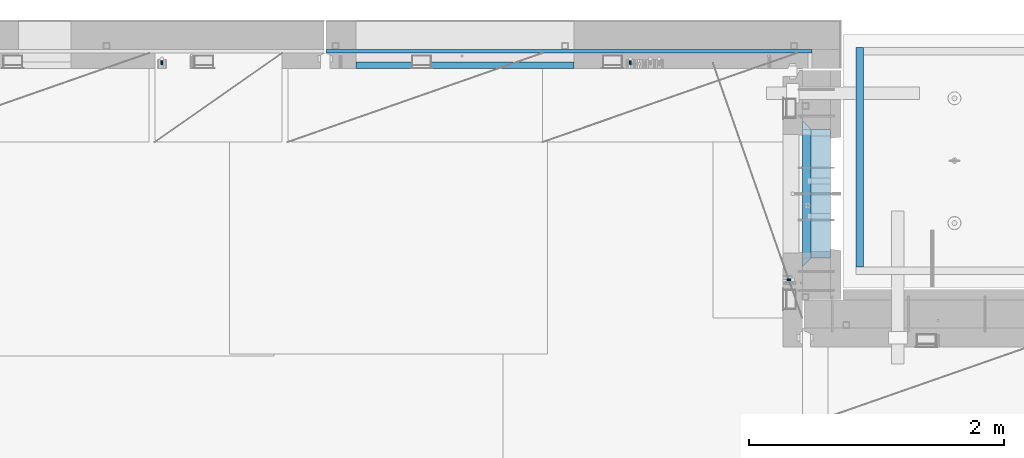
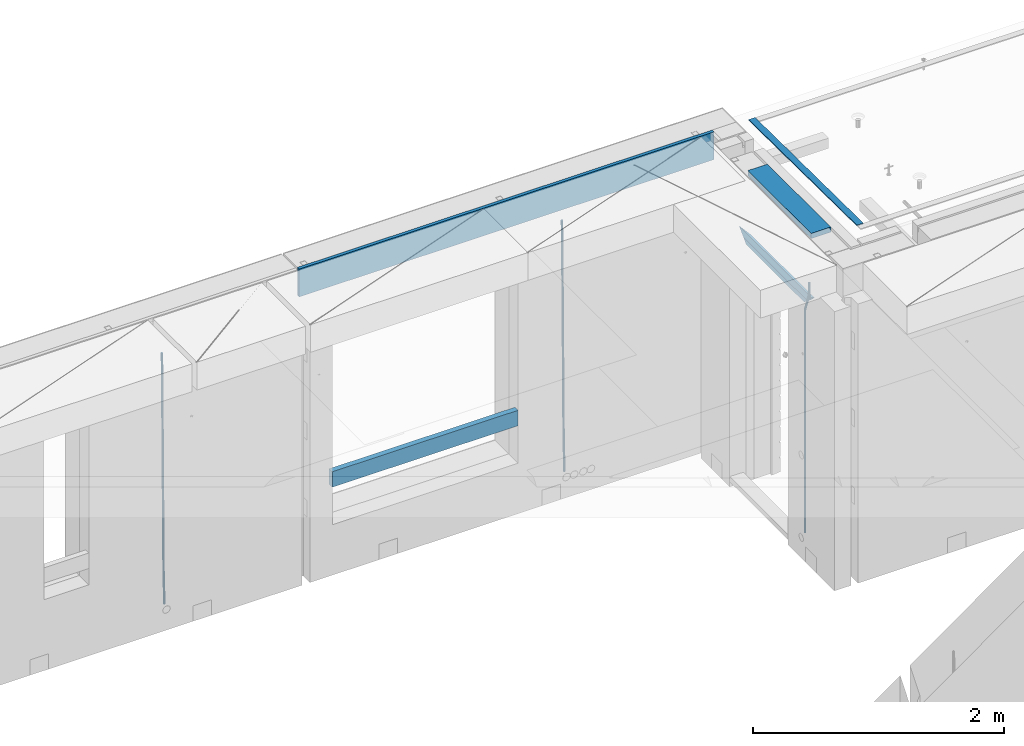
# One storey, part 122 of 341: 9 beams, 4 elements without a shape of their own.
"""IFC2X3 building model written with IfcOpenShell, lengths in millimetres."""

from ifc_helpers import new_model, si_unit, frame, origin_with_axes, place, context, subcontext, project, spatial, faceted_brep, material, type_object, element, aggregate, save


model = new_model("IFC2X3")

# Units and contexts
model_context = context("Model", 3, precision=1e-05, world=origin_with_axes())
body_context = subcontext(model_context, "Body", "Model", "MODEL_VIEW")
ifc_project = project(units=[si_unit("LENGTHUNIT", "METRE", prefix="MILLI"), si_unit("AREAUNIT", "SQUARE_METRE"), si_unit("VOLUMEUNIT", "CUBIC_METRE"), si_unit("MASSUNIT", "GRAM", prefix="KILO"), si_unit("TIMEUNIT", "SECOND"), si_unit("PLANEANGLEUNIT", "RADIAN"), si_unit("SOLIDANGLEUNIT", "STERADIAN"), si_unit("THERMODYNAMICTEMPERATUREUNIT", "DEGREE_CELSIUS"), si_unit("LUMINOUSINTENSITYUNIT", "LUMEN")], contexts=[model_context])

# Site, building, storey
site_placement = place(None, origin_with_axes())
site = spatial("IfcSite", under=ifc_project, at=site_placement, CompositionType="ELEMENT")
building_placement = place(site_placement, origin_with_axes())
building = spatial("IfcBuilding", under=site, at=building_placement, CompositionType="ELEMENT")
storey_placement = place(building_placement, origin_with_axes())
storey = spatial("IfcBuildingStorey", under=building, at=storey_placement, Name="5", CompositionType="ELEMENT", Elevation=0.0)

# Assembly, beams
assembly_1_placement = place(storey_placement, origin_with_axes())
assembly_1 = element("IfcElementAssembly", 1, at=assembly_1_placement, inside=storey, AssemblyPlace="NOTDEFINED", PredefinedType="REINFORCEMENT_UNIT")
ifc_material_1 = material(Name="CONCRETE/C25/30")
beam_type_1 = type_object("IfcBeamType", PredefinedType="NOTDEFINED")
beam_1_placement = place(assembly_1_placement, frame((31494.9951872276, 21060.0002716511, 96140.0), z_axis=(0.0, 0.0, -1.0), x_axis=(0.0, 1.0, 0.0)))
beam_1 = element("IfcBeam", 2, at=beam_1_placement, type_object=beam_type_1, material=ifc_material_1, Name="SK", context=body_context, shape_type="Brep", body=[
    faceted_brep([(70.0000000000164, -35.0, 35.0), (70.0000000000164, 35.0, 35.0), (0.0, -35.0, -35.0), (1079.99961853027, 35.0, 35.0), (1149.99961853027, -35.0, -35.0), (1079.99961853027, -35.0, 35.0)], [[[0, 1, 2]], [[2, 1, 3, 4]], [[0, 2, 4, 5]], [[1, 0, 5, 3]], [[4, 3, 5]]]),
])
beam_type_2 = type_object("IfcBeamType", PredefinedType="NOTDEFINED")
beam_2_placement = place(assembly_1_placement, frame((31494.9951872276, 21130.0002716511, 96080.0), z_axis=(0.0, 0.0, -1.0), x_axis=(0.0, 1.0, 0.0)))
beam_2 = element("IfcBeam", 3, at=beam_2_placement, type_object=beam_type_2, material=ifc_material_1, Name="SK", context=body_context, shape_type="Brep", body=[
    faceted_brep([(0.0, -35.0, -25.0), (43.8457723764295, -35.0, 18.8461538461561), (45.6406441713007, 35.0, 20.6410256410309), (0.0, 35.0, -25.0), (1009.99961853027, 35.0, -25.0), (1009.99961853027, -35.0, -25.0), (966.153464684117, -35.0, 18.8461538461561), (964.358592889246, 35.0, 20.6410256410309)], [[[0, 1, 2, 3]], [[0, 3, 4, 5]], [[1, 0, 5, 6]], [[6, 7, 2, 1]], [[3, 2, 7, 4]], [[6, 5, 4, 7]]]),
])

# Assembly, beam
assembly_2_placement = place(storey_placement, origin_with_axes())
assembly_2 = element("IfcElementAssembly", 4, at=assembly_2_placement, inside=storey, AssemblyPlace="NOTDEFINED", PredefinedType="REINFORCEMENT_UNIT")
ifc_material_2 = material()
beam_type_3 = type_object("IfcBeamType", Name="D20", PredefinedType="NOTDEFINED")
beam_3_placement = place(assembly_2_placement, frame((30110.0000000039, 22654.9999977209, 93990.0), z_axis=(-0.000205762999925498, 0.999642804629538, -0.0267249099901004), x_axis=(4.30000201928125e-08, 0.0267249099948059, 0.999642825806181)))
beam_3 = element("IfcBeam", 5, at=beam_3_placement, type_object=beam_type_3, material=ifc_material_2, Name="JM20", ObjectType="D20", context=body_context, shape_type="Brep", body=[
    faceted_brep([(0.0, -10.0, 0.0), (-4.19531716033816e-08, -7.07106781186667, -7.07106781187031), (60.4266690400545, -7.0710677960451, -7.07106780570757), (60.4266690441291, -9.99999998418934, 6.15546014159918e-09), (0.0, 0.0, -10.0), (60.426669036824, 1.58106558956206e-08, -9.99999999384454), (4.196772351861e-08, 7.07106781186303, -7.07106781186667), (60.4266690363438, 7.07106782768096, -7.07106780570757), (0.0, 10.0, 0.0), (60.4266690388904, 10.0000000158179, 6.15182216279209e-09), (4.196772351861e-08, 7.07106781185939, 7.07106781185939), (60.4266690429649, 7.07106782768096, 7.07106781802577), (0.0, 0.0, 10.0), (60.4266690461809, 1.58179318532348e-08, 10.0000000061555), (-4.19531716033816e-08, -7.07106781187031, 7.07106781185939), (60.4266690466611, -7.07106779605238, 7.07106781802213), (61.0378400410118, -7.07106779588503, -7.07106780564936), (60.991799419251, -9.99999998403655, 6.21366780251265e-09), (61.0569027789461, 1.5985278878361e-08, -9.99999999378269), (61.0378209396877, 7.07106782784831, -7.07106780564936), (60.9917724058905, 10.0000000159635, 6.21366780251265e-09), (60.9457317841297, 7.07106782781193, 7.0710678180767), (60.9266690461809, 1.59488990902901e-08, 10.0000000062028), (60.9457508854539, -7.07106779591413, 7.0710678180767), (61.6489592143771, -7.07106614513759, -7.06310863441468), (61.5568818710308, -9.9999984576425, 0.00735959856683621), (61.6870830769039, 1.71821739058942e-06, -9.99179257185824), (61.6489210170112, 7.07106947854481, -7.06310888312146), (61.556827851804, 10.0000015422847, 0.00735924683976918), (61.4647505084577, 7.07106922979438, 7.07782747982128), (61.4266266459163, 1.36643211590126e-06, 10.0065114172685), (61.464788705809, -7.07106639389531, 7.07782772852806), (176.543135720174, -7.07075579406956, -5.56673531796696), (176.451058376813, -9.99968810657447, 1.50373291501455), (176.581259582701, 0.000312069292704109, -8.49541925541052), (176.543097522794, 7.07137982961285, -5.56673556667374), (176.451004357587, 10.00031189336, 1.50373256329476), (176.35892701424, 7.07137958085514, 8.57420079627263), (176.320803151699, 0.000311717507429421, 11.5028847337162), (176.358965211621, -7.07075604281999, 8.57420104497578), (177.098753836006, -7.07075429323595, -5.55949898843028), (176.98362511232, -9.99968666800123, 1.510669025065), (177.146421932586, 0.000313595905026887, -8.48805862247536), (177.098706077581, 7.07138133041735, -5.55949936166144), (176.983557571715, 10.0003133318824, 1.51066849724157), (176.868428848029, 7.07138095712435, 8.58083651073321), (176.820760751449, 0.000313067976094317, 11.5093961447819), (176.868476606425, -7.07075466652896, 8.58083688396073), (177.654312950661, -7.07075204110879, -5.54863964998367), (177.516135294456, -9.99968450931192, 1.52107783331303), (177.711524267797, 0.000315886711177882, -8.47701274570863), (177.654255632195, 7.07138358250813, -5.54864021007961), (177.516054233929, 10.0003154905207, 1.5210770412159), (177.377876577739, 7.0713830223176, 8.59079452451624), (177.320665260588, 0.000315094497636892, 11.5191676202448), (177.377933896176, -7.07075260129932, 8.59079508461218), (299.436796249574, -7.07025836271714, -3.1681962331204), (299.298618593355, -9.99919083092027, 3.90152125031091), (299.494007566798, 0.000809565110102994, -6.09656932889993), (299.436738931283, 7.07187726089978, -3.16819679320906), (299.298537533061, 10.0008091689197, 3.90152045822106), (299.160359876842, 7.07187670072017, 10.9712379416487), (299.103148559603, 0.000808772889286047, 13.8996110374392), (299.160417195119, -7.07025892290039, 10.9712385017483), (299.98743051647, -7.07025613056248, -3.15743315966392), (299.971788958996, -9.99918809853989, 3.91467979818117), (299.993912075952, 0.000811591617093654, -6.08679785393178), (299.987423933868, 7.07187949325817, -3.1574327280432), (299.971753863239, 10.0008119014747, 3.91467990454839), (299.95611230444, 7.07187992653053, 10.9867922621015), (299.949630744944, 0.000812204350950196, 13.9161569563694), (299.956118887014, -7.07025569729012, 10.9867918304735), (300.538107039494, -7.07025785017686, -3.16575821840888), (300.644985195438, -9.99919020432935, 3.90450175465594), (300.493854948218, 0.000810030429420294, -6.09435592770024), (300.538151196495, 7.071877773491, -3.16575855385963), (300.645047642858, 10.0008097955724, 3.90450128024895), (300.751925798773, 7.07187744142357, 10.9747612533101), (300.796177890064, 0.000809560813650023, 13.9033589625978), (300.751881641787, -7.07025818224065, 10.9747615887682), (2293.36490490142, -7.07648090940347, -33.2930642912361), (2293.47178305736, -10.0054132635523, -26.2228043181785), (2293.32065281013, -0.00541302880083094, -36.2216620005347), (2293.36494905842, 7.06565471425711, -33.2930646266868), (2293.47184550477, 9.99458673634581, -26.2228047925819), (2293.57872366071, 7.06565438219332, -19.1525448195243), (2293.62297575199, -0.00541349841296324, -16.2239471102366), (2293.57867950371, -7.0764812414709, -19.1525444840736), (2294.0658245362, -7.07648309818615, -33.3036607065333), (2294.05312277409, -10.0054150789219, -26.2315929392535), (2294.10928714235, -0.00541549149056664, -36.2335844756526), (2294.15805078732, 7.06565223761572, -33.3050546393533), (2294.18355038921, 9.99458451388637, -26.2335642579346), (2294.17084862708, 7.06565253314329, -19.1614964906439), (2294.12738602093, -0.00541507354500936, -16.2315727215355), (2294.07862237596, -7.07648280265857, -19.1601025578348), (2294.76670261032, -7.08562269121467, -33.294332712383), (2294.63442802057, -10.0129954178956, -26.2238563411993), (2294.89787471293, -0.0156988342423574, -36.2230891548279), (2294.95110548967, 7.05531064255774, -33.2944998654275), (2294.89521307347, 9.98530428734011, -26.2240927312887), (2294.76293848372, 7.0579315606592, -19.1536163601049), (2294.63176638114, -0.0119922963167483, -16.2248599176673), (2294.57853560438, -7.08300177311321, -19.1534492070678), (2316.52657204497, -7.36937582653991, -33.0047303660212), (2316.39429745522, -10.2967485532172, -25.9342539948302), (2316.65774414754, -0.299451969567599, -35.9334868084661), (2316.7109749243, 6.7715575072325, -33.0048975190657), (2316.65508250811, 9.70155115201487, -25.9344903849269), (2316.52280791836, 6.7741784253376, -18.8640140137468), (2316.39163581574, -0.295745431634714, -15.9352575713092), (2316.33840503903, -7.36675490843481, -18.863846860706), (2317.16202064224, -7.37766220584308, -32.9962731735213), (2317.05438744847, -10.3053562613532, -25.9254688497131), (2317.23607125619, -0.306993473008333, -35.925789846493), (2317.23316144495, 6.76474808850253, -32.9979477328052), (2317.15499573652, 9.6950321815566, -25.9278370341635), (2317.04736254275, 6.7673381260538, -18.8570327103698), (2316.97331192881, -0.303330606784584, -15.9275160373909), (2316.97622174003, -7.37507216829545, -18.8553581510787), (2317.79752306276, -7.37578610372293, -32.9880110666527), (2317.71453320107, -10.3033876998124, -25.9168792378296), (2317.81444760226, -0.305295583297266, -35.918287695793), (2317.75539265381, 6.76628640723357, -32.9911928173897), (2317.65495180529, 9.69652304524061, -25.9213789128698), (2317.5719619436, 6.76892144914746, -18.8502470840467), (2317.55503740412, -0.301569071270933, -15.9199704549137), (2317.61409235255, -7.3731510618054, -18.847065333317), (2417.8183084176, -7.07752398473531, -31.6906369377139), (2417.73531855589, -10.0051255808248, -24.6195051088798), (2417.83523295709, -0.007033464313281, -34.6209135668432), (2417.77617800863, 7.06454852621755, -31.6938186884508), (2417.67573716014, 9.99478516423187, -24.6240047839383), (2417.59274729842, 7.06718356813872, -17.5528729551006), (2417.57582275895, -0.00330695228694822, -14.6225963259749), (2417.6348777074, -7.07488894281778, -17.5496912043673)], [[[0, 1, 2, 3]], [[1, 4, 5, 2]], [[4, 6, 7, 5]], [[6, 8, 9, 7]], [[8, 10, 11, 9]], [[10, 12, 13, 11]], [[12, 14, 15, 13]], [[14, 0, 3, 15]], [[14, 12, 10, 8, 6, 4, 1, 0]], [[3, 2, 16, 17]], [[2, 5, 18, 16]], [[5, 7, 19, 18]], [[7, 9, 20, 19]], [[9, 11, 21, 20]], [[11, 13, 22, 21]], [[13, 15, 23, 22]], [[15, 3, 17, 23]], [[17, 16, 24, 25]], [[16, 18, 26, 24]], [[18, 19, 27, 26]], [[19, 20, 28, 27]], [[20, 21, 29, 28]], [[21, 22, 30, 29]], [[22, 23, 31, 30]], [[23, 17, 25, 31]], [[25, 24, 32, 33]], [[24, 26, 34, 32]], [[26, 27, 35, 34]], [[27, 28, 36, 35]], [[28, 29, 37, 36]], [[29, 30, 38, 37]], [[30, 31, 39, 38]], [[31, 25, 33, 39]], [[33, 32, 40, 41]], [[32, 34, 42, 40]], [[34, 35, 43, 42]], [[35, 36, 44, 43]], [[36, 37, 45, 44]], [[37, 38, 46, 45]], [[38, 39, 47, 46]], [[39, 33, 41, 47]], [[41, 40, 48, 49]], [[40, 42, 50, 48]], [[42, 43, 51, 50]], [[43, 44, 52, 51]], [[44, 45, 53, 52]], [[45, 46, 54, 53]], [[46, 47, 55, 54]], [[47, 41, 49, 55]], [[49, 48, 56, 57]], [[48, 50, 58, 56]], [[50, 51, 59, 58]], [[51, 52, 60, 59]], [[52, 53, 61, 60]], [[53, 54, 62, 61]], [[54, 55, 63, 62]], [[55, 49, 57, 63]], [[57, 56, 64, 65]], [[56, 58, 66, 64]], [[58, 59, 67, 66]], [[59, 60, 68, 67]], [[60, 61, 69, 68]], [[61, 62, 70, 69]], [[62, 63, 71, 70]], [[63, 57, 65, 71]], [[65, 64, 72, 73]], [[64, 66, 74, 72]], [[66, 67, 75, 74]], [[67, 68, 76, 75]], [[68, 69, 77, 76]], [[69, 70, 78, 77]], [[70, 71, 79, 78]], [[71, 65, 73, 79]], [[73, 72, 80, 81]], [[72, 74, 82, 80]], [[74, 75, 83, 82]], [[75, 76, 84, 83]], [[76, 77, 85, 84]], [[77, 78, 86, 85]], [[78, 79, 87, 86]], [[79, 73, 81, 87]], [[81, 80, 88, 89]], [[80, 82, 90, 88]], [[82, 83, 91, 90]], [[83, 84, 92, 91]], [[84, 85, 93, 92]], [[85, 86, 94, 93]], [[86, 87, 95, 94]], [[87, 81, 89, 95]], [[89, 88, 96, 97]], [[88, 90, 98, 96]], [[90, 91, 99, 98]], [[91, 92, 100, 99]], [[92, 93, 101, 100]], [[93, 94, 102, 101]], [[94, 95, 103, 102]], [[95, 89, 97, 103]], [[97, 96, 104, 105]], [[96, 98, 106, 104]], [[98, 99, 107, 106]], [[99, 100, 108, 107]], [[100, 101, 109, 108]], [[101, 102, 110, 109]], [[102, 103, 111, 110]], [[103, 97, 105, 111]], [[105, 104, 112, 113]], [[104, 106, 114, 112]], [[106, 107, 115, 114]], [[107, 108, 116, 115]], [[108, 109, 117, 116]], [[109, 110, 118, 117]], [[110, 111, 119, 118]], [[111, 105, 113, 119]], [[113, 112, 120, 121]], [[112, 114, 122, 120]], [[114, 115, 123, 122]], [[115, 116, 124, 123]], [[116, 117, 125, 124]], [[117, 118, 126, 125]], [[118, 119, 127, 126]], [[119, 113, 121, 127]], [[121, 120, 128, 129]], [[120, 122, 130, 128]], [[122, 123, 131, 130]], [[123, 124, 132, 131]], [[124, 125, 133, 132]], [[125, 126, 134, 133]], [[126, 127, 135, 134]], [[127, 121, 129, 135]], [[130, 131, 132, 133, 134, 135, 129, 128]]]),
])

assembly_3_placement = place(storey_placement, origin_with_axes())
assembly_3 = element("IfcElementAssembly", 6, at=assembly_3_placement, inside=storey, AssemblyPlace="NOTDEFINED", PredefinedType="REINFORCEMENT_UNIT")
beam_4_placement = place(assembly_3_placement, frame((26430.0000000039, 22654.999995444, 93990.0), z_axis=(-0.000205762999925498, 0.999642804629538, -0.0267249099901004), x_axis=(4.30000201928125e-08, 0.0267249099948059, 0.999642825806181)))
beam_4 = element("IfcBeam", 7, at=beam_4_placement, type_object=beam_type_3, material=ifc_material_2, Name="JM20", ObjectType="D20", context=body_context, shape_type="Brep", body=[
    faceted_brep([(0.0, -10.0, 0.0), (-4.19531716033816e-08, -7.07106781186667, -7.07106781187031), (60.4266690400545, -7.0710677960451, -7.07106780570757), (60.4266690441291, -9.99999998418934, 6.15546014159918e-09), (0.0, 0.0, -10.0), (60.426669036824, 1.58106558956206e-08, -9.99999999384454), (4.196772351861e-08, 7.07106781186303, -7.07106781186667), (60.4266690363438, 7.07106782768096, -7.07106780570757), (0.0, 10.0, 0.0), (60.4266690388904, 10.0000000158179, 6.15182216279209e-09), (4.196772351861e-08, 7.07106781185939, 7.07106781185939), (60.4266690429649, 7.07106782768096, 7.07106781802577), (0.0, 0.0, 10.0), (60.4266690461809, 1.58179318532348e-08, 10.0000000061555), (-4.19531716033816e-08, -7.07106781187031, 7.07106781185939), (60.4266690466611, -7.07106779605238, 7.07106781802213), (61.0378400410118, -7.07106779588503, -7.07106780564936), (60.991799419251, -9.99999998403655, 6.21366780251265e-09), (61.0569027789461, 1.5985278878361e-08, -9.99999999378269), (61.0378209396877, 7.07106782784831, -7.07106780564936), (60.9917724058905, 10.0000000159635, 6.21366780251265e-09), (60.9457317841297, 7.07106782781193, 7.0710678180767), (60.9266690461809, 1.59488990902901e-08, 10.0000000062028), (60.9457508854539, -7.07106779591413, 7.0710678180767), (61.6489592143771, -7.07106614513759, -7.06310863441468), (61.5568818710308, -9.9999984576425, 0.00735959856683621), (61.6870830769039, 1.71821739058942e-06, -9.99179257185824), (61.6489210170112, 7.07106947854481, -7.06310888312146), (61.556827851804, 10.0000015422847, 0.00735924683976918), (61.4647505084577, 7.07106922979438, 7.07782747982128), (61.4266266459163, 1.36643211590126e-06, 10.0065114172685), (61.464788705809, -7.07106639389531, 7.07782772852806), (176.543135720174, -7.07075579406956, -5.56673531796696), (176.451058376813, -9.99968810657447, 1.50373291501455), (176.581259582701, 0.000312069292704109, -8.49541925541052), (176.543097522794, 7.07137982961285, -5.56673556667374), (176.451004357587, 10.00031189336, 1.50373256329476), (176.35892701424, 7.07137958085514, 8.57420079627263), (176.320803151699, 0.000311717507429421, 11.5028847337162), (176.358965211621, -7.07075604281999, 8.57420104497578), (177.098753836006, -7.07075429323595, -5.55949898843028), (176.98362511232, -9.99968666800123, 1.510669025065), (177.146421932586, 0.000313595905026887, -8.48805862247536), (177.098706077581, 7.07138133041735, -5.55949936166144), (176.983557571715, 10.0003133318824, 1.51066849724157), (176.868428848029, 7.07138095712435, 8.58083651073321), (176.820760751449, 0.000313067976094317, 11.5093961447819), (176.868476606425, -7.07075466652896, 8.58083688396073), (177.654312950661, -7.07075204110879, -5.54863964998367), (177.516135294456, -9.99968450931192, 1.52107783331303), (177.711524267797, 0.000315886711177882, -8.47701274570863), (177.654255632195, 7.07138358250813, -5.54864021007961), (177.516054233929, 10.0003154905207, 1.5210770412159), (177.377876577739, 7.0713830223176, 8.59079452451624), (177.320665260588, 0.000315094497636892, 11.5191676202448), (177.377933896176, -7.07075260129932, 8.59079508461218), (299.436796249574, -7.07025836271714, -3.1681962331204), (299.298618593355, -9.99919083092027, 3.90152125031091), (299.494007566798, 0.000809565110102994, -6.09656932889993), (299.436738931283, 7.07187726089978, -3.16819679320906), (299.298537533061, 10.0008091689197, 3.90152045822106), (299.160359876842, 7.07187670072017, 10.9712379416487), (299.103148559603, 0.000808772889286047, 13.8996110374392), (299.160417195119, -7.07025892290039, 10.9712385017483), (299.98743051647, -7.07025613056248, -3.15743315966392), (299.971788958996, -9.99918809853989, 3.91467979818117), (299.993912075952, 0.000811591617093654, -6.08679785393178), (299.987423933868, 7.07187949325817, -3.1574327280432), (299.971753863239, 10.0008119014747, 3.91467990454839), (299.95611230444, 7.07187992653053, 10.9867922621015), (299.949630744944, 0.000812204350950196, 13.9161569563694), (299.956118887014, -7.07025569729012, 10.9867918304735), (300.538107039494, -7.07025785017686, -3.16575821840888), (300.644985195438, -9.99919020432935, 3.90450175465594), (300.493854948218, 0.000810030429420294, -6.09435592770024), (300.538151196495, 7.071877773491, -3.16575855385963), (300.645047642858, 10.0008097955724, 3.90450128024895), (300.751925798773, 7.07187744142357, 10.9747612533101), (300.796177890064, 0.000809560813650023, 13.9033589625978), (300.751881641787, -7.07025818224065, 10.9747615887682), (2293.36490490142, -7.07648090940347, -33.2930642912361), (2293.47178305736, -10.0054132635523, -26.2228043181785), (2293.32065281013, -0.00541302880083094, -36.2216620005347), (2293.36494905842, 7.06565471425711, -33.2930646266868), (2293.47184550477, 9.99458673634581, -26.2228047925819), (2293.57872366071, 7.06565438219332, -19.1525448195243), (2293.62297575199, -0.00541349841296324, -16.2239471102366), (2293.57867950371, -7.0764812414709, -19.1525444840736), (2294.0658245362, -7.07648309818615, -33.3036607065333), (2294.05312277409, -10.0054150789219, -26.2315929392535), (2294.10928714235, -0.00541549149056664, -36.2335844756526), (2294.15805078732, 7.06565223761572, -33.3050546393533), (2294.18355038921, 9.99458451388637, -26.2335642579346), (2294.17084862708, 7.06565253314329, -19.1614964906439), (2294.12738602093, -0.00541507354500936, -16.2315727215355), (2294.07862237596, -7.07648280265857, -19.1601025578348), (2294.76670261032, -7.08562269121467, -33.294332712383), (2294.63442802057, -10.0129954178956, -26.2238563411993), (2294.89787471293, -0.0156988342423574, -36.2230891548279), (2294.95110548967, 7.05531064255774, -33.2944998654275), (2294.89521307347, 9.98530428734011, -26.2240927312887), (2294.76293848372, 7.0579315606592, -19.1536163601049), (2294.63176638114, -0.0119922963167483, -16.2248599176673), (2294.57853560438, -7.08300177311321, -19.1534492070678), (2316.52657204497, -7.36937582653991, -33.0047303660212), (2316.39429745522, -10.2967485532172, -25.9342539948302), (2316.65774414754, -0.299451969567599, -35.9334868084661), (2316.7109749243, 6.7715575072325, -33.0048975190657), (2316.65508250811, 9.70155115201487, -25.9344903849269), (2316.52280791836, 6.7741784253376, -18.8640140137468), (2316.39163581574, -0.295745431634714, -15.9352575713092), (2316.33840503903, -7.36675490843481, -18.863846860706), (2317.16202064224, -7.37766220584308, -32.9962731735213), (2317.05438744847, -10.3053562613532, -25.9254688497131), (2317.23607125619, -0.306993473008333, -35.925789846493), (2317.23316144495, 6.76474808850253, -32.9979477328052), (2317.15499573652, 9.6950321815566, -25.9278370341635), (2317.04736254275, 6.7673381260538, -18.8570327103698), (2316.97331192881, -0.303330606784584, -15.9275160373909), (2316.97622174003, -7.37507216829545, -18.8553581510787), (2317.79752306276, -7.37578610372293, -32.9880110666527), (2317.71453320107, -10.3033876998124, -25.9168792378296), (2317.81444760226, -0.305295583297266, -35.918287695793), (2317.75539265381, 6.76628640723357, -32.9911928173897), (2317.65495180529, 9.69652304524061, -25.9213789128698), (2317.5719619436, 6.76892144914746, -18.8502470840467), (2317.55503740412, -0.301569071270933, -15.9199704549137), (2317.61409235255, -7.3731510618054, -18.847065333317), (2417.8183084176, -7.07752398473531, -31.6906369377139), (2417.73531855589, -10.0051255808248, -24.6195051088798), (2417.83523295709, -0.007033464313281, -34.6209135668432), (2417.77617800863, 7.06454852621755, -31.6938186884508), (2417.67573716014, 9.99478516423187, -24.6240047839383), (2417.59274729842, 7.06718356813872, -17.5528729551006), (2417.57582275895, -0.00330695228694822, -14.6225963259749), (2417.6348777074, -7.07488894281778, -17.5496912043673)], [[[0, 1, 2, 3]], [[1, 4, 5, 2]], [[4, 6, 7, 5]], [[6, 8, 9, 7]], [[8, 10, 11, 9]], [[10, 12, 13, 11]], [[12, 14, 15, 13]], [[14, 0, 3, 15]], [[14, 12, 10, 8, 6, 4, 1, 0]], [[3, 2, 16, 17]], [[2, 5, 18, 16]], [[5, 7, 19, 18]], [[7, 9, 20, 19]], [[9, 11, 21, 20]], [[11, 13, 22, 21]], [[13, 15, 23, 22]], [[15, 3, 17, 23]], [[17, 16, 24, 25]], [[16, 18, 26, 24]], [[18, 19, 27, 26]], [[19, 20, 28, 27]], [[20, 21, 29, 28]], [[21, 22, 30, 29]], [[22, 23, 31, 30]], [[23, 17, 25, 31]], [[25, 24, 32, 33]], [[24, 26, 34, 32]], [[26, 27, 35, 34]], [[27, 28, 36, 35]], [[28, 29, 37, 36]], [[29, 30, 38, 37]], [[30, 31, 39, 38]], [[31, 25, 33, 39]], [[33, 32, 40, 41]], [[32, 34, 42, 40]], [[34, 35, 43, 42]], [[35, 36, 44, 43]], [[36, 37, 45, 44]], [[37, 38, 46, 45]], [[38, 39, 47, 46]], [[39, 33, 41, 47]], [[41, 40, 48, 49]], [[40, 42, 50, 48]], [[42, 43, 51, 50]], [[43, 44, 52, 51]], [[44, 45, 53, 52]], [[45, 46, 54, 53]], [[46, 47, 55, 54]], [[47, 41, 49, 55]], [[49, 48, 56, 57]], [[48, 50, 58, 56]], [[50, 51, 59, 58]], [[51, 52, 60, 59]], [[52, 53, 61, 60]], [[53, 54, 62, 61]], [[54, 55, 63, 62]], [[55, 49, 57, 63]], [[57, 56, 64, 65]], [[56, 58, 66, 64]], [[58, 59, 67, 66]], [[59, 60, 68, 67]], [[60, 61, 69, 68]], [[61, 62, 70, 69]], [[62, 63, 71, 70]], [[63, 57, 65, 71]], [[65, 64, 72, 73]], [[64, 66, 74, 72]], [[66, 67, 75, 74]], [[67, 68, 76, 75]], [[68, 69, 77, 76]], [[69, 70, 78, 77]], [[70, 71, 79, 78]], [[71, 65, 73, 79]], [[73, 72, 80, 81]], [[72, 74, 82, 80]], [[74, 75, 83, 82]], [[75, 76, 84, 83]], [[76, 77, 85, 84]], [[77, 78, 86, 85]], [[78, 79, 87, 86]], [[79, 73, 81, 87]], [[81, 80, 88, 89]], [[80, 82, 90, 88]], [[82, 83, 91, 90]], [[83, 84, 92, 91]], [[84, 85, 93, 92]], [[85, 86, 94, 93]], [[86, 87, 95, 94]], [[87, 81, 89, 95]], [[89, 88, 96, 97]], [[88, 90, 98, 96]], [[90, 91, 99, 98]], [[91, 92, 100, 99]], [[92, 93, 101, 100]], [[93, 94, 102, 101]], [[94, 95, 103, 102]], [[95, 89, 97, 103]], [[97, 96, 104, 105]], [[96, 98, 106, 104]], [[98, 99, 107, 106]], [[99, 100, 108, 107]], [[100, 101, 109, 108]], [[101, 102, 110, 109]], [[102, 103, 111, 110]], [[103, 97, 105, 111]], [[105, 104, 112, 113]], [[104, 106, 114, 112]], [[106, 107, 115, 114]], [[107, 108, 116, 115]], [[108, 109, 117, 116]], [[109, 110, 118, 117]], [[110, 111, 119, 118]], [[111, 105, 113, 119]], [[113, 112, 120, 121]], [[112, 114, 122, 120]], [[114, 115, 123, 122]], [[115, 116, 124, 123]], [[116, 117, 125, 124]], [[117, 118, 126, 125]], [[118, 119, 127, 126]], [[119, 113, 121, 127]], [[121, 120, 128, 129]], [[120, 122, 130, 128]], [[122, 123, 131, 130]], [[123, 124, 132, 131]], [[124, 125, 133, 132]], [[125, 126, 134, 133]], [[126, 127, 135, 134]], [[127, 121, 129, 135]], [[130, 131, 132, 133, 134, 135, 129, 128]]]),
])
aggregate(assembly_3, [beam_4])

# Beam
beam_5_placement = place(assembly_1_placement, frame((31384.9951872298, 20959.9999999916, 96407.5), z_axis=(-0.999999913638316, 0.000415599999849952, 0.0), x_axis=(0.0, 0.0, -1.0)))
beam_5 = element("IfcBeam", 8, at=beam_5_placement, type_object=beam_type_3, material=ifc_material_2, Name="JM20", ObjectType="D20", context=body_context, shape_type="Brep", body=[
    faceted_brep([(0.0, -10.0, 0.0), (-4.19531716033816e-08, -7.07106781186667, -7.07106781187031), (113.248091332178, -7.0710684840451, -7.0710678117357), (113.248091314759, -10.0000006713562, -2.51020537689328e-10), (0.0, 0.0, -10.0), (113.248091374131, -6.72178430249915e-07, -9.99999999986903), (4.196772351861e-08, 7.07106781186303, -7.07106781186667), (113.248091416113, 7.07106713968824, -7.07106781173934), (0.0, 10.0, 0.0), (113.248091433488, 9.99999932782521, 1.30967237055302e-10), (4.196772351861e-08, 7.07106781185939, 7.07106781185939), (113.248091416113, 7.0710671396846, 7.071067811994), (0.0, 0.0, 10.0), (113.248091374131, -6.72174792271107e-07, 10.0000000001273), (-4.19531716033816e-08, -7.07106781187031, 7.07106781185939), (113.248091332178, -7.0710684840451, 7.071067811994), (130.699843527167, -7.06993249763036, -4.33745683788584), (128.538066582521, -9.99900540317321, 2.39499413731755), (131.594536475241, 0.00119355250353692, -7.12624594330919), (130.698046432328, 7.07220300913468, -4.33773834422391), (128.535525107087, 10.0009944322555, 2.39459602660281), (126.373748162892, 7.07192152754578, 9.1270470011732), (125.479055214906, 0.000795477419160306, 11.9158361066184), (126.37554525779, -7.07021397921199, 9.12732850753673), (240.336258550378, -7.05529970173666, 30.8729495437874), (238.174481606227, -9.98437260450009, 37.6054005176375), (241.230951498423, 0.0158263482953771, 28.0841604381058), (240.334461455612, 7.0868358050102, 30.8726680369582), (238.171940130502, 10.0156272283348, 37.6050024077231), (236.010163186409, 7.08655432384694, 44.3374533824244), (235.115470238379, 0.0154282738185429, 47.1262424881097), (236.011960281176, -7.05558118289991, 44.3377348892536), (253.461915329972, -7.05444528127919, 32.9289287376414), (253.46191532613, -9.98337746617108, 39.9999965521893), (253.461915339081, 0.0166225284556276, 29.9999965443676), (253.461915348205, 7.08769034247234, 32.9289287273205), (253.461915352003, 10.0166225357716, 39.9999965370152), (253.461915348293, 7.08769035281148, 47.0710643509774), (253.461915339183, 0.0166225430875784, 49.999996544273), (253.46191533003, -7.05444527093641, 47.0710643613093), (2417.50000002384, -7.0544364694706, 32.9289287374122), (2417.5000000337, -9.98336865393321, 39.9999965507959), (2417.49999999997, 0.0166313408753922, 29.9999965456082), (2417.49999997609, 7.08769915426274, 32.9289287300708), (2417.4999999662, 10.0166313460668, 39.9999965404204), (2417.49999997608, 7.08769916160054, 47.0710643538114), (2417.49999999994, 0.0166313512581837, 49.9999965456154), (2417.50000002382, -7.05443646212916, 47.0710643611455)], [[[0, 1, 2, 3]], [[1, 4, 5, 2]], [[4, 6, 7, 5]], [[6, 8, 9, 7]], [[8, 10, 11, 9]], [[10, 12, 13, 11]], [[12, 14, 15, 13]], [[14, 0, 3, 15]], [[14, 12, 10, 8, 6, 4, 1, 0]], [[3, 2, 16, 17]], [[2, 5, 18, 16]], [[5, 7, 19, 18]], [[7, 9, 20, 19]], [[9, 11, 21, 20]], [[11, 13, 22, 21]], [[13, 15, 23, 22]], [[15, 3, 17, 23]], [[17, 16, 24, 25]], [[16, 18, 26, 24]], [[18, 19, 27, 26]], [[19, 20, 28, 27]], [[20, 21, 29, 28]], [[21, 22, 30, 29]], [[22, 23, 31, 30]], [[23, 17, 25, 31]], [[25, 24, 32, 33]], [[24, 26, 34, 32]], [[26, 27, 35, 34]], [[27, 28, 36, 35]], [[28, 29, 37, 36]], [[29, 30, 38, 37]], [[30, 31, 39, 38]], [[31, 25, 33, 39]], [[33, 32, 40, 41]], [[32, 34, 42, 40]], [[34, 35, 43, 42]], [[35, 36, 44, 43]], [[36, 37, 45, 44]], [[37, 38, 46, 45]], [[38, 39, 47, 46]], [[39, 33, 41, 47]], [[42, 43, 44, 45, 46, 47, 41, 40]]]),
])

ifc_material_3 = material(Name="TIMBER/T24")
beam_type_4 = type_object("IfcBeamType", PredefinedType="NOTDEFINED")
beam_6_placement = place(assembly_2_placement, frame((29665.0002980493, 22644.9998418812, 94685.0), z_axis=(0.0, 0.0, 1.0), x_axis=(-1.0, 3.00000001838171e-08, 0.0)))
beam_6 = element("IfcBeam", 9, at=beam_6_placement, type_object=beam_type_4, material=ifc_material_3, context=body_context, shape_type="Brep", body=[
    faceted_brep([(-3.63797880709171e-12, 24.9999999999964, -75.0), (-3.63797880709171e-12, 24.9999999999964, 75.0), (1710.0, 25.0, 75.0), (1710.0, 25.0, -75.0), (0.0, -25.0000000000073, 75.0), (1709.99999999999, -25.0, 75.0), (0.0, -25.0000000000073, -75.0), (1709.99999999999, -25.0, -75.0)], [[[0, 1, 2, 3]], [[1, 4, 5, 2]], [[4, 6, 7, 5]], [[6, 0, 3, 7]], [[5, 7, 3, 2]], [[6, 4, 1, 0]]]),
])

# Assembly, beam
assembly_4_placement = place(storey_placement, origin_with_axes())
assembly_4 = element("IfcElementAssembly", 10, at=assembly_4_placement, inside=storey, AssemblyPlace="NOTDEFINED", PredefinedType="REINFORCEMENT_UNIT")
ifc_material_4 = material(Name="CONCRETE/Concrete_Undefined")
beam_type_5 = type_object("IfcBeamType", PredefinedType="NOTDEFINED")
beam_7_placement = place(assembly_4_placement, frame((31909.9986098709, 21060.0524822207, 96725.2791116282), z_axis=(7.99999906921644e-09, 0.0107912409985276, 0.999941772863656), x_axis=(7.22999999800065e-07, 0.999941772863395, -0.0107912409985247)))
beam_7 = element("IfcBeam", 11, at=beam_7_placement, type_object=beam_type_5, material=ifc_material_4, context=body_context, shape_type="Brep", body=[
    faceted_brep([(2.5465851649642e-11, 29.9999999999982, -4.99999999998545), (-2.91038304567337e-11, 29.9999999999982, 5.0), (1725.04446838825, 29.9999999999927, 4.99999999998545), (1725.04446838825, 29.9999999999927, -5.00000000001455), (-2.5465851649642e-11, -30.0000000000018, 5.0), (1725.04446838824, -30.0000000000073, 4.99999999998545), (2.72848410531878e-11, -30.0000000000018, -4.99999999998545), (1725.04446838824, -30.0000000000073, -5.0)], [[[0, 1, 2, 3]], [[1, 4, 5, 2]], [[4, 6, 7, 5]], [[6, 0, 3, 7]], [[5, 7, 3, 2]], [[6, 4, 1, 0]]]),
])
aggregate(assembly_4, [beam_7])

# Beam
beam_type_6 = type_object("IfcBeamType", Name="270X30", PredefinedType="NOTDEFINED")
beam_8_placement = place(assembly_2_placement, frame((31535.0, 22755.0, 96605.0), z_axis=(0.0, 0.0, 1.0), x_axis=(-1.0, 3.00000001838171e-08, 0.0)))
beam_8 = element("IfcBeam", 12, at=beam_8_placement, type_object=beam_type_6, material=ifc_material_1, ObjectType="270X30", context=body_context, shape_type="Brep", body=[
    faceted_brep([(0.0, 15.0, -135.0), (0.0, 15.0, 135.0), (3815.00000000003, 15.0, 135.0), (3815.00000000003, 15.0, -135.0), (0.0, -15.0, 135.0), (3815.00000000003, -15.0, 135.0), (0.0, -15.0, -135.0), (3815.00000000003, -15.0, -135.0)], [[[0, 1, 2, 3]], [[1, 4, 5, 2]], [[4, 6, 7, 5]], [[6, 0, 3, 7]], [[5, 7, 3, 2]], [[6, 4, 1, 0]]]),
])

aggregate(assembly_2, [beam_3, beam_8, beam_6])

ifc_material_5 = material(Name="TIMBER")
beam_type_7 = type_object("IfcBeamType", PredefinedType="NOTDEFINED")
beam_9_placement = place(assembly_1_placement, frame((31589.9951872276, 22140.0000381475, 96715.0), z_axis=(0.0, 0.0, 1.0), x_axis=(0.0, -1.0, 0.0)))
beam_9 = element("IfcBeam", 13, at=beam_9_placement, type_object=beam_type_7, material=ifc_material_5, context=body_context, shape_type="Brep", body=[
    faceted_brep([(0.0, 90.0, -25.0), (0.0, 90.0, 25.0), (1009.99983857082, 90.0, 25.0), (1009.99983857082, 90.0, -25.0), (0.0, -90.0, 25.0), (1009.99983857082, -90.0, 25.0), (0.0, -90.0, -25.0), (1009.99983857082, -90.0, -25.0)], [[[0, 1, 2, 3]], [[1, 4, 5, 2]], [[4, 6, 7, 5]], [[6, 0, 3, 7]], [[5, 7, 3, 2]], [[6, 4, 1, 0]]]),
])

aggregate(assembly_1, [beam_5, beam_9, beam_1, beam_2])

save(model, "model.ifc")
